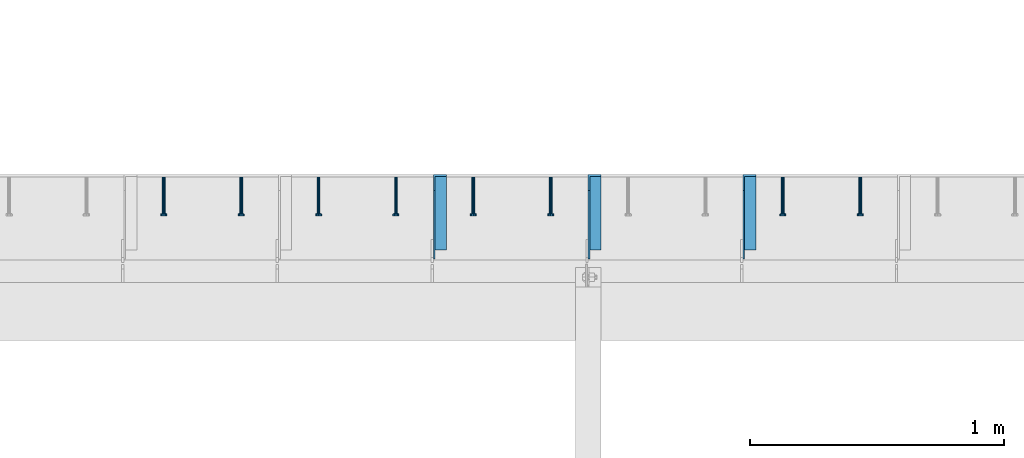
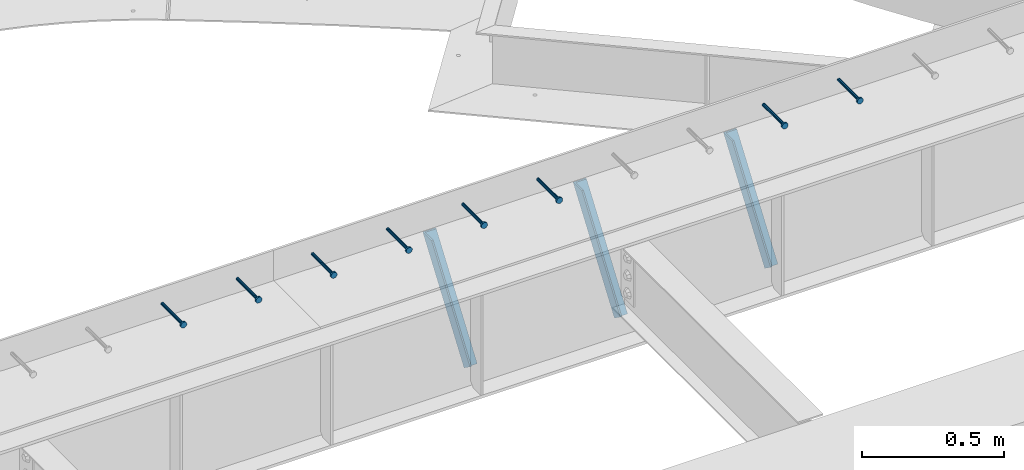
# One storey, part 1350 of 1763: 8 beams, 3 members, 9 elements without a shape of their own.
"""IFC2X3 building model written with IfcOpenShell, lengths in millimetres."""

from ifc_helpers import new_model, si_unit, frame, origin_with_axes, place, context, subcontext, project, spatial, faceted_brep, material, type_object, element, aggregate, save


model = new_model("IFC2X3")

# Units and contexts
model_context = context("Model", 3, precision=1e-05, world=origin_with_axes())
body_context = subcontext(model_context, "Body", "Model", "MODEL_VIEW")
ifc_project = project(units=[si_unit("LENGTHUNIT", "METRE", prefix="MILLI"), si_unit("AREAUNIT", "SQUARE_METRE"), si_unit("VOLUMEUNIT", "CUBIC_METRE"), si_unit("MASSUNIT", "GRAM", prefix="KILO"), si_unit("TIMEUNIT", "SECOND"), si_unit("PLANEANGLEUNIT", "RADIAN"), si_unit("SOLIDANGLEUNIT", "STERADIAN"), si_unit("THERMODYNAMICTEMPERATUREUNIT", "DEGREE_CELSIUS"), si_unit("LUMINOUSINTENSITYUNIT", "LUMEN")], contexts=[model_context])

# Site, building, storey
site_placement = place(None, origin_with_axes())
site = spatial("IfcSite", under=ifc_project, at=site_placement, CompositionType="ELEMENT")
building_placement = place(site_placement, origin_with_axes())
building = spatial("IfcBuilding", under=site, at=building_placement, Name="Undefined", CompositionType="ELEMENT")
storey_placement = place(building_placement, origin_with_axes())
storey = spatial("IfcBuildingStorey", under=building, at=storey_placement, Name="Undefined", CompositionType="ELEMENT", Elevation=0.0)

# Assembly, beam
assembly_1_placement = place(storey_placement, origin_with_axes())
assembly_1 = element("IfcElementAssembly", 1, at=assembly_1_placement, inside=storey, Name="HEADED STUD ANCHOR", AssemblyPlace="NOTDEFINED", PredefinedType="RIGID_FRAME")
ifc_material_1 = material(Name="STEEL/A108")
beam_type = type_object("IfcBeamType", PredefinedType="NOTDEFINED")
beam_1_placement = place(assembly_1_placement, frame((-53207.6747736983, 53984.5250183106, 5264.23140606069), z_axis=(0.0, 0.0, 1.0), x_axis=(0.0, -1.0, 0.0)))
beam_1 = element("IfcBeam", 2, at=beam_1_placement, type_object=beam_type, material=ifc_material_1, Name="HEADED STUD ANCHOR", context=body_context, shape_type="Brep", body=[
    faceted_brep([(0.0, -3.1800000667572, 5.5), (0.0, -5.5, 3.1800000667572), (141.732000000002, -5.5, 3.1800000667572), (141.732000000002, -3.1800000667572, 5.5), (0.0, -6.34999999999491, 1.45519152283669e-11), (141.732000000002, -6.34999990463257, 0.0), (0.0, -5.5, -3.1800000667572), (141.732000000002, -5.5, -3.1800000667572), (0.0, -3.1800000667572, -5.5), (141.732000000002, -3.1800000667572, -5.5), (0.0, 0.0, -6.34999990463257), (141.732000000002, 0.0, -6.34999990463257), (0.0, 3.1800000667572, -5.5), (141.732000000002, 3.1800000667572, -5.5), (0.0, 5.5, -3.1800000667572), (141.732000000002, 5.5, -3.1800000667572), (0.0, 6.34999999999491, -2.91038304567337e-11), (141.732000000002, 6.34999990463257, 0.0), (0.0, 5.5, 3.1800000667572), (141.732000000002, 5.5, 3.1800000667572), (0.0, 3.1800000667572, 5.5), (141.732000000002, 3.1800000667572, 5.5), (0.0, 0.0, 6.34999990463257), (141.732000000002, 0.0, 6.34999990463257), (144.780000000001, -10.9899997711182, 6.34999990463257), (144.780000000001, -6.34000015258789, 10.9899997711182), (144.780000000001, -12.6999998092651, 0.0), (144.780000000001, -10.9899997711182, -6.34999990463257), (144.780000000001, -6.34000015258789, -10.9899997711182), (144.780000000001, 0.0, -12.6899995803833), (144.780000000001, 6.34000015258789, -10.9899997711182), (144.780000000001, 10.9899997711182, -6.34999990463257), (144.780000000001, 12.6999998092651, 0.0), (144.780000000001, 10.9899997711182, 6.34999990463257), (144.780000000001, 6.34000015258789, 10.9899997711182), (144.780000000001, 0.0, 12.6899995803833), (152.400000000001, -10.9899997711182, 6.34999990463257), (152.400000000001, -6.34000015258789, 10.9899997711182), (152.400000000001, -12.6999998092651, 0.0), (152.400000000001, -10.9899997711182, -6.34999990463257), (152.400000000001, -6.34000015258789, -10.9899997711182), (152.400000000001, 0.0, -12.6899995803833), (152.400000000001, 6.34000015258789, -10.9899997711182), (152.400000000001, 10.9899997711182, -6.34999990463257), (152.400000000001, 12.6999998092651, 0.0), (152.400000000001, 10.9899997711182, 6.34999990463257), (152.400000000001, 6.34000015258789, 10.9899997711182), (152.400000000001, 0.0, 12.6899995803833)], [[[0, 1, 2, 3]], [[1, 4, 5, 2]], [[4, 6, 7, 5]], [[6, 8, 9, 7]], [[8, 10, 11, 9]], [[10, 12, 13, 11]], [[12, 14, 15, 13]], [[14, 16, 17, 15]], [[16, 18, 19, 17]], [[18, 20, 21, 19]], [[20, 22, 23, 21]], [[22, 0, 3, 23]], [[22, 20, 18, 16, 14, 12, 10, 8, 6, 4, 1, 0]], [[3, 2, 24, 25]], [[2, 5, 26, 24]], [[5, 7, 27, 26]], [[7, 9, 28, 27]], [[9, 11, 29, 28]], [[11, 13, 30, 29]], [[13, 15, 31, 30]], [[15, 17, 32, 31]], [[17, 19, 33, 32]], [[19, 21, 34, 33]], [[21, 23, 35, 34]], [[23, 3, 25, 35]], [[25, 24, 36, 37]], [[24, 26, 38, 36]], [[26, 27, 39, 38]], [[27, 28, 40, 39]], [[28, 29, 41, 40]], [[29, 30, 42, 41]], [[30, 31, 43, 42]], [[31, 32, 44, 43]], [[32, 33, 45, 44]], [[33, 34, 46, 45]], [[34, 35, 47, 46]], [[35, 25, 37, 47]], [[38, 39, 40, 41, 42, 43, 44, 45, 46, 47, 37, 36]]]),
])
aggregate(assembly_1, [beam_1])

assembly_2_placement = place(storey_placement, origin_with_axes())
assembly_2 = element("IfcElementAssembly", 3, at=assembly_2_placement, inside=storey, Name="HEADED STUD ANCHOR", AssemblyPlace="NOTDEFINED", PredefinedType="RIGID_FRAME")
beam_2_placement = place(assembly_2_placement, frame((-53512.4747736983, 53984.5250183106, 5264.23140606069), z_axis=(0.0, 0.0, 1.0), x_axis=(0.0, -1.0, 0.0)))
beam_2 = element("IfcBeam", 4, at=beam_2_placement, type_object=beam_type, material=ifc_material_1, Name="HEADED STUD ANCHOR", context=body_context, shape_type="Brep", body=[
    faceted_brep([(0.0, -3.1800000667572, 5.5), (0.0, -5.5, 3.1800000667572), (141.732000000002, -5.5, 3.1800000667572), (141.732000000002, -3.1800000667572, 5.5), (0.0, -6.34999999999491, 1.45519152283669e-11), (141.732000000002, -6.34999990463257, 0.0), (0.0, -5.5, -3.1800000667572), (141.732000000002, -5.5, -3.1800000667572), (0.0, -3.1800000667572, -5.5), (141.732000000002, -3.1800000667572, -5.5), (0.0, 0.0, -6.34999990463257), (141.732000000002, 0.0, -6.34999990463257), (0.0, 3.1800000667572, -5.5), (141.732000000002, 3.1800000667572, -5.5), (0.0, 5.5, -3.1800000667572), (141.732000000002, 5.5, -3.1800000667572), (0.0, 6.34999999999491, -2.91038304567337e-11), (141.732000000002, 6.34999990463257, 0.0), (0.0, 5.5, 3.1800000667572), (141.732000000002, 5.5, 3.1800000667572), (0.0, 3.1800000667572, 5.5), (141.732000000002, 3.1800000667572, 5.5), (0.0, 0.0, 6.34999990463257), (141.732000000002, 0.0, 6.34999990463257), (144.780000000001, -10.9899997711182, 6.34999990463257), (144.780000000001, -6.34000015258789, 10.9899997711182), (144.780000000001, -12.6999998092651, 0.0), (144.780000000001, -10.9899997711182, -6.34999990463257), (144.780000000001, -6.34000015258789, -10.9899997711182), (144.780000000001, 0.0, -12.6899995803833), (144.780000000001, 6.34000015258789, -10.9899997711182), (144.780000000001, 10.9899997711182, -6.34999990463257), (144.780000000001, 12.6999998092651, 0.0), (144.780000000001, 10.9899997711182, 6.34999990463257), (144.780000000001, 6.34000015258789, 10.9899997711182), (144.780000000001, 0.0, 12.6899995803833), (152.400000000001, -10.9899997711182, 6.34999990463257), (152.400000000001, -6.34000015258789, 10.9899997711182), (152.400000000001, -12.6999998092651, 0.0), (152.400000000001, -10.9899997711182, -6.34999990463257), (152.400000000001, -6.34000015258789, -10.9899997711182), (152.400000000001, 0.0, -12.6899995803833), (152.400000000001, 6.34000015258789, -10.9899997711182), (152.400000000001, 10.9899997711182, -6.34999990463257), (152.400000000001, 12.6999998092651, 0.0), (152.400000000001, 10.9899997711182, 6.34999990463257), (152.400000000001, 6.34000015258789, 10.9899997711182), (152.400000000001, 0.0, 12.6899995803833)], [[[0, 1, 2, 3]], [[1, 4, 5, 2]], [[4, 6, 7, 5]], [[6, 8, 9, 7]], [[8, 10, 11, 9]], [[10, 12, 13, 11]], [[12, 14, 15, 13]], [[14, 16, 17, 15]], [[16, 18, 19, 17]], [[18, 20, 21, 19]], [[20, 22, 23, 21]], [[22, 0, 3, 23]], [[22, 20, 18, 16, 14, 12, 10, 8, 6, 4, 1, 0]], [[3, 2, 24, 25]], [[2, 5, 26, 24]], [[5, 7, 27, 26]], [[7, 9, 28, 27]], [[9, 11, 29, 28]], [[11, 13, 30, 29]], [[13, 15, 31, 30]], [[15, 17, 32, 31]], [[17, 19, 33, 32]], [[19, 21, 34, 33]], [[21, 23, 35, 34]], [[23, 3, 25, 35]], [[25, 24, 36, 37]], [[24, 26, 38, 36]], [[26, 27, 39, 38]], [[27, 28, 40, 39]], [[28, 29, 41, 40]], [[29, 30, 42, 41]], [[30, 31, 43, 42]], [[31, 32, 44, 43]], [[32, 33, 45, 44]], [[33, 34, 46, 45]], [[34, 35, 47, 46]], [[35, 25, 37, 47]], [[38, 39, 40, 41, 42, 43, 44, 45, 46, 47, 37, 36]]]),
])
aggregate(assembly_2, [beam_2])

assembly_3_placement = place(storey_placement, origin_with_axes())
assembly_3 = element("IfcElementAssembly", 5, at=assembly_3_placement, inside=storey, Name="HEADED STUD ANCHOR", AssemblyPlace="NOTDEFINED", PredefinedType="RIGID_FRAME")
beam_3_placement = place(assembly_3_placement, frame((-54426.8747736983, 53984.5250183106, 5264.23140606069), z_axis=(0.0, 0.0, 1.0), x_axis=(0.0, -1.0, 0.0)))
beam_3 = element("IfcBeam", 6, at=beam_3_placement, type_object=beam_type, material=ifc_material_1, Name="HEADED STUD ANCHOR", context=body_context, shape_type="Brep", body=[
    faceted_brep([(0.0, -3.1800000667572, 5.5), (0.0, -5.5, 3.1800000667572), (141.732000000002, -5.5, 3.1800000667572), (141.732000000002, -3.1800000667572, 5.5), (0.0, -6.34999999999491, 1.45519152283669e-11), (141.732000000002, -6.34999990463257, 0.0), (0.0, -5.5, -3.1800000667572), (141.732000000002, -5.5, -3.1800000667572), (0.0, -3.1800000667572, -5.5), (141.732000000002, -3.1800000667572, -5.5), (0.0, 0.0, -6.34999990463257), (141.732000000002, 0.0, -6.34999990463257), (0.0, 3.1800000667572, -5.5), (141.732000000002, 3.1800000667572, -5.5), (0.0, 5.5, -3.1800000667572), (141.732000000002, 5.5, -3.1800000667572), (0.0, 6.34999999999491, -2.91038304567337e-11), (141.732000000002, 6.34999990463257, 0.0), (0.0, 5.5, 3.1800000667572), (141.732000000002, 5.5, 3.1800000667572), (0.0, 3.1800000667572, 5.5), (141.732000000002, 3.1800000667572, 5.5), (0.0, 0.0, 6.34999990463257), (141.732000000002, 0.0, 6.34999990463257), (144.780000000001, -10.9899997711182, 6.34999990463257), (144.780000000001, -6.34000015258789, 10.9899997711182), (144.780000000001, -12.6999998092651, 0.0), (144.780000000001, -10.9899997711182, -6.34999990463257), (144.780000000001, -6.34000015258789, -10.9899997711182), (144.780000000001, 0.0, -12.6899995803833), (144.780000000001, 6.34000015258789, -10.9899997711182), (144.780000000001, 10.9899997711182, -6.34999990463257), (144.780000000001, 12.6999998092651, 0.0), (144.780000000001, 10.9899997711182, 6.34999990463257), (144.780000000001, 6.34000015258789, 10.9899997711182), (144.780000000001, 0.0, 12.6899995803833), (152.400000000001, -10.9899997711182, 6.34999990463257), (152.400000000001, -6.34000015258789, 10.9899997711182), (152.400000000001, -12.6999998092651, 0.0), (152.400000000001, -10.9899997711182, -6.34999990463257), (152.400000000001, -6.34000015258789, -10.9899997711182), (152.400000000001, 0.0, -12.6899995803833), (152.400000000001, 6.34000015258789, -10.9899997711182), (152.400000000001, 10.9899997711182, -6.34999990463257), (152.400000000001, 12.6999998092651, 0.0), (152.400000000001, 10.9899997711182, 6.34999990463257), (152.400000000001, 6.34000015258789, 10.9899997711182), (152.400000000001, 0.0, 12.6899995803833)], [[[0, 1, 2, 3]], [[1, 4, 5, 2]], [[4, 6, 7, 5]], [[6, 8, 9, 7]], [[8, 10, 11, 9]], [[10, 12, 13, 11]], [[12, 14, 15, 13]], [[14, 16, 17, 15]], [[16, 18, 19, 17]], [[18, 20, 21, 19]], [[20, 22, 23, 21]], [[22, 0, 3, 23]], [[22, 20, 18, 16, 14, 12, 10, 8, 6, 4, 1, 0]], [[3, 2, 24, 25]], [[2, 5, 26, 24]], [[5, 7, 27, 26]], [[7, 9, 28, 27]], [[9, 11, 29, 28]], [[11, 13, 30, 29]], [[13, 15, 31, 30]], [[15, 17, 32, 31]], [[17, 19, 33, 32]], [[19, 21, 34, 33]], [[21, 23, 35, 34]], [[23, 3, 25, 35]], [[25, 24, 36, 37]], [[24, 26, 38, 36]], [[26, 27, 39, 38]], [[27, 28, 40, 39]], [[28, 29, 41, 40]], [[29, 30, 42, 41]], [[30, 31, 43, 42]], [[31, 32, 44, 43]], [[32, 33, 45, 44]], [[33, 34, 46, 45]], [[34, 35, 47, 46]], [[35, 25, 37, 47]], [[38, 39, 40, 41, 42, 43, 44, 45, 46, 47, 37, 36]]]),
])
aggregate(assembly_3, [beam_3])

assembly_4_placement = place(storey_placement, origin_with_axes())
assembly_4 = element("IfcElementAssembly", 7, at=assembly_4_placement, inside=storey, Name="HEADED STUD ANCHOR", AssemblyPlace="NOTDEFINED", PredefinedType="RIGID_FRAME")
beam_4_placement = place(assembly_4_placement, frame((-54731.6747736983, 53984.5250183106, 5264.23140606069), z_axis=(0.0, 0.0, 1.0), x_axis=(0.0, -1.0, 0.0)))
beam_4 = element("IfcBeam", 8, at=beam_4_placement, type_object=beam_type, material=ifc_material_1, Name="HEADED STUD ANCHOR", context=body_context, shape_type="Brep", body=[
    faceted_brep([(0.0, -3.1800000667572, 5.5), (0.0, -5.5, 3.1800000667572), (141.732000000002, -5.5, 3.1800000667572), (141.732000000002, -3.1800000667572, 5.5), (0.0, -6.34999999999491, 1.45519152283669e-11), (141.732000000002, -6.34999990463257, 0.0), (0.0, -5.5, -3.1800000667572), (141.732000000002, -5.5, -3.1800000667572), (0.0, -3.1800000667572, -5.5), (141.732000000002, -3.1800000667572, -5.5), (0.0, 0.0, -6.34999990463257), (141.732000000002, 0.0, -6.34999990463257), (0.0, 3.1800000667572, -5.5), (141.732000000002, 3.1800000667572, -5.5), (0.0, 5.5, -3.1800000667572), (141.732000000002, 5.5, -3.1800000667572), (0.0, 6.34999999999491, -2.91038304567337e-11), (141.732000000002, 6.34999990463257, 0.0), (0.0, 5.5, 3.1800000667572), (141.732000000002, 5.5, 3.1800000667572), (0.0, 3.1800000667572, 5.5), (141.732000000002, 3.1800000667572, 5.5), (0.0, 0.0, 6.34999990463257), (141.732000000002, 0.0, 6.34999990463257), (144.780000000001, -10.9899997711182, 6.34999990463257), (144.780000000001, -6.34000015258789, 10.9899997711182), (144.780000000001, -12.6999998092651, 0.0), (144.780000000001, -10.9899997711182, -6.34999990463257), (144.780000000001, -6.34000015258789, -10.9899997711182), (144.780000000001, 0.0, -12.6899995803833), (144.780000000001, 6.34000015258789, -10.9899997711182), (144.780000000001, 10.9899997711182, -6.34999990463257), (144.780000000001, 12.6999998092651, 0.0), (144.780000000001, 10.9899997711182, 6.34999990463257), (144.780000000001, 6.34000015258789, 10.9899997711182), (144.780000000001, 0.0, 12.6899995803833), (152.400000000001, -10.9899997711182, 6.34999990463257), (152.400000000001, -6.34000015258789, 10.9899997711182), (152.400000000001, -12.6999998092651, 0.0), (152.400000000001, -10.9899997711182, -6.34999990463257), (152.400000000001, -6.34000015258789, -10.9899997711182), (152.400000000001, 0.0, -12.6899995803833), (152.400000000001, 6.34000015258789, -10.9899997711182), (152.400000000001, 10.9899997711182, -6.34999990463257), (152.400000000001, 12.6999998092651, 0.0), (152.400000000001, 10.9899997711182, 6.34999990463257), (152.400000000001, 6.34000015258789, 10.9899997711182), (152.400000000001, 0.0, 12.6899995803833)], [[[0, 1, 2, 3]], [[1, 4, 5, 2]], [[4, 6, 7, 5]], [[6, 8, 9, 7]], [[8, 10, 11, 9]], [[10, 12, 13, 11]], [[12, 14, 15, 13]], [[14, 16, 17, 15]], [[16, 18, 19, 17]], [[18, 20, 21, 19]], [[20, 22, 23, 21]], [[22, 0, 3, 23]], [[22, 20, 18, 16, 14, 12, 10, 8, 6, 4, 1, 0]], [[3, 2, 24, 25]], [[2, 5, 26, 24]], [[5, 7, 27, 26]], [[7, 9, 28, 27]], [[9, 11, 29, 28]], [[11, 13, 30, 29]], [[13, 15, 31, 30]], [[15, 17, 32, 31]], [[17, 19, 33, 32]], [[19, 21, 34, 33]], [[21, 23, 35, 34]], [[23, 3, 25, 35]], [[25, 24, 36, 37]], [[24, 26, 38, 36]], [[26, 27, 39, 38]], [[27, 28, 40, 39]], [[28, 29, 41, 40]], [[29, 30, 42, 41]], [[30, 31, 43, 42]], [[31, 32, 44, 43]], [[32, 33, 45, 44]], [[33, 34, 46, 45]], [[34, 35, 47, 46]], [[35, 25, 37, 47]], [[38, 39, 40, 41, 42, 43, 44, 45, 46, 47, 37, 36]]]),
])
aggregate(assembly_4, [beam_4])

assembly_5_placement = place(storey_placement, origin_with_axes())
assembly_5 = element("IfcElementAssembly", 9, at=assembly_5_placement, inside=storey, Name="HEADED STUD ANCHOR", AssemblyPlace="NOTDEFINED", PredefinedType="RIGID_FRAME")
beam_5_placement = place(assembly_5_placement, frame((-55036.4747736983, 53984.5250183106, 5264.23140606069), z_axis=(0.0, 0.0, 1.0), x_axis=(0.0, -1.0, 0.0)))
beam_5 = element("IfcBeam", 10, at=beam_5_placement, type_object=beam_type, material=ifc_material_1, Name="HEADED STUD ANCHOR", context=body_context, shape_type="Brep", body=[
    faceted_brep([(0.0, -3.1800000667572, 5.5), (0.0, -5.5, 3.1800000667572), (141.732000000002, -5.5, 3.1800000667572), (141.732000000002, -3.1800000667572, 5.5), (0.0, -6.34999999999491, 1.45519152283669e-11), (141.732000000002, -6.34999990463257, 0.0), (0.0, -5.5, -3.1800000667572), (141.732000000002, -5.5, -3.1800000667572), (0.0, -3.1800000667572, -5.5), (141.732000000002, -3.1800000667572, -5.5), (0.0, 0.0, -6.34999990463257), (141.732000000002, 0.0, -6.34999990463257), (0.0, 3.1800000667572, -5.5), (141.732000000002, 3.1800000667572, -5.5), (0.0, 5.5, -3.1800000667572), (141.732000000002, 5.5, -3.1800000667572), (0.0, 6.34999999999491, -2.91038304567337e-11), (141.732000000002, 6.34999990463257, 0.0), (0.0, 5.5, 3.1800000667572), (141.732000000002, 5.5, 3.1800000667572), (0.0, 3.1800000667572, 5.5), (141.732000000002, 3.1800000667572, 5.5), (0.0, 0.0, 6.34999990463257), (141.732000000002, 0.0, 6.34999990463257), (144.780000000001, -10.9899997711182, 6.34999990463257), (144.780000000001, -6.34000015258789, 10.9899997711182), (144.780000000001, -12.6999998092651, 0.0), (144.780000000001, -10.9899997711182, -6.34999990463257), (144.780000000001, -6.34000015258789, -10.9899997711182), (144.780000000001, 0.0, -12.6899995803833), (144.780000000001, 6.34000015258789, -10.9899997711182), (144.780000000001, 10.9899997711182, -6.34999990463257), (144.780000000001, 12.6999998092651, 0.0), (144.780000000001, 10.9899997711182, 6.34999990463257), (144.780000000001, 6.34000015258789, 10.9899997711182), (144.780000000001, 0.0, 12.6899995803833), (152.400000000001, -10.9899997711182, 6.34999990463257), (152.400000000001, -6.34000015258789, 10.9899997711182), (152.400000000001, -12.6999998092651, 0.0), (152.400000000001, -10.9899997711182, -6.34999990463257), (152.400000000001, -6.34000015258789, -10.9899997711182), (152.400000000001, 0.0, -12.6899995803833), (152.400000000001, 6.34000015258789, -10.9899997711182), (152.400000000001, 10.9899997711182, -6.34999990463257), (152.400000000001, 12.6999998092651, 0.0), (152.400000000001, 10.9899997711182, 6.34999990463257), (152.400000000001, 6.34000015258789, 10.9899997711182), (152.400000000001, 0.0, 12.6899995803833)], [[[0, 1, 2, 3]], [[1, 4, 5, 2]], [[4, 6, 7, 5]], [[6, 8, 9, 7]], [[8, 10, 11, 9]], [[10, 12, 13, 11]], [[12, 14, 15, 13]], [[14, 16, 17, 15]], [[16, 18, 19, 17]], [[18, 20, 21, 19]], [[20, 22, 23, 21]], [[22, 0, 3, 23]], [[22, 20, 18, 16, 14, 12, 10, 8, 6, 4, 1, 0]], [[3, 2, 24, 25]], [[2, 5, 26, 24]], [[5, 7, 27, 26]], [[7, 9, 28, 27]], [[9, 11, 29, 28]], [[11, 13, 30, 29]], [[13, 15, 31, 30]], [[15, 17, 32, 31]], [[17, 19, 33, 32]], [[19, 21, 34, 33]], [[21, 23, 35, 34]], [[23, 3, 25, 35]], [[25, 24, 36, 37]], [[24, 26, 38, 36]], [[26, 27, 39, 38]], [[27, 28, 40, 39]], [[28, 29, 41, 40]], [[29, 30, 42, 41]], [[30, 31, 43, 42]], [[31, 32, 44, 43]], [[32, 33, 45, 44]], [[33, 34, 46, 45]], [[34, 35, 47, 46]], [[35, 25, 37, 47]], [[38, 39, 40, 41, 42, 43, 44, 45, 46, 47, 37, 36]]]),
])
aggregate(assembly_5, [beam_5])

assembly_6_placement = place(storey_placement, origin_with_axes())
assembly_6 = element("IfcElementAssembly", 11, at=assembly_6_placement, inside=storey, Name="HEADED STUD ANCHOR", AssemblyPlace="NOTDEFINED", PredefinedType="RIGID_FRAME")
beam_6_placement = place(assembly_6_placement, frame((-55341.2747736983, 53984.5250183106, 5264.23140606069), z_axis=(0.0, 0.0, 1.0), x_axis=(0.0, -1.0, 0.0)))
beam_6 = element("IfcBeam", 12, at=beam_6_placement, type_object=beam_type, material=ifc_material_1, Name="HEADED STUD ANCHOR", context=body_context, shape_type="Brep", body=[
    faceted_brep([(0.0, -3.1800000667572, 5.5), (0.0, -5.5, 3.1800000667572), (141.732000000002, -5.5, 3.1800000667572), (141.732000000002, -3.1800000667572, 5.5), (0.0, -6.34999999999491, 1.45519152283669e-11), (141.732000000002, -6.34999990463257, 0.0), (0.0, -5.5, -3.1800000667572), (141.732000000002, -5.5, -3.1800000667572), (0.0, -3.1800000667572, -5.5), (141.732000000002, -3.1800000667572, -5.5), (0.0, 0.0, -6.34999990463257), (141.732000000002, 0.0, -6.34999990463257), (0.0, 3.1800000667572, -5.5), (141.732000000002, 3.1800000667572, -5.5), (0.0, 5.5, -3.1800000667572), (141.732000000002, 5.5, -3.1800000667572), (0.0, 6.34999999999491, -2.91038304567337e-11), (141.732000000002, 6.34999990463257, 0.0), (0.0, 5.5, 3.1800000667572), (141.732000000002, 5.5, 3.1800000667572), (0.0, 3.1800000667572, 5.5), (141.732000000002, 3.1800000667572, 5.5), (0.0, 0.0, 6.34999990463257), (141.732000000002, 0.0, 6.34999990463257), (144.780000000001, -10.9899997711182, 6.34999990463257), (144.780000000001, -6.34000015258789, 10.9899997711182), (144.780000000001, -12.6999998092651, 0.0), (144.780000000001, -10.9899997711182, -6.34999990463257), (144.780000000001, -6.34000015258789, -10.9899997711182), (144.780000000001, 0.0, -12.6899995803833), (144.780000000001, 6.34000015258789, -10.9899997711182), (144.780000000001, 10.9899997711182, -6.34999990463257), (144.780000000001, 12.6999998092651, 0.0), (144.780000000001, 10.9899997711182, 6.34999990463257), (144.780000000001, 6.34000015258789, 10.9899997711182), (144.780000000001, 0.0, 12.6899995803833), (152.400000000001, -10.9899997711182, 6.34999990463257), (152.400000000001, -6.34000015258789, 10.9899997711182), (152.400000000001, -12.6999998092651, 0.0), (152.400000000001, -10.9899997711182, -6.34999990463257), (152.400000000001, -6.34000015258789, -10.9899997711182), (152.400000000001, 0.0, -12.6899995803833), (152.400000000001, 6.34000015258789, -10.9899997711182), (152.400000000001, 10.9899997711182, -6.34999990463257), (152.400000000001, 12.6999998092651, 0.0), (152.400000000001, 10.9899997711182, 6.34999990463257), (152.400000000001, 6.34000015258789, 10.9899997711182), (152.400000000001, 0.0, 12.6899995803833)], [[[0, 1, 2, 3]], [[1, 4, 5, 2]], [[4, 6, 7, 5]], [[6, 8, 9, 7]], [[8, 10, 11, 9]], [[10, 12, 13, 11]], [[12, 14, 15, 13]], [[14, 16, 17, 15]], [[16, 18, 19, 17]], [[18, 20, 21, 19]], [[20, 22, 23, 21]], [[22, 0, 3, 23]], [[22, 20, 18, 16, 14, 12, 10, 8, 6, 4, 1, 0]], [[3, 2, 24, 25]], [[2, 5, 26, 24]], [[5, 7, 27, 26]], [[7, 9, 28, 27]], [[9, 11, 29, 28]], [[11, 13, 30, 29]], [[13, 15, 31, 30]], [[15, 17, 32, 31]], [[17, 19, 33, 32]], [[19, 21, 34, 33]], [[21, 23, 35, 34]], [[23, 3, 25, 35]], [[25, 24, 36, 37]], [[24, 26, 38, 36]], [[26, 27, 39, 38]], [[27, 28, 40, 39]], [[28, 29, 41, 40]], [[29, 30, 42, 41]], [[30, 31, 43, 42]], [[31, 32, 44, 43]], [[32, 33, 45, 44]], [[33, 34, 46, 45]], [[34, 35, 47, 46]], [[35, 25, 37, 47]], [[38, 39, 40, 41, 42, 43, 44, 45, 46, 47, 37, 36]]]),
])
aggregate(assembly_6, [beam_6])

assembly_7_placement = place(storey_placement, origin_with_axes())
assembly_7 = element("IfcElementAssembly", 13, at=assembly_7_placement, inside=storey, Name="HEADED STUD ANCHOR", AssemblyPlace="NOTDEFINED", PredefinedType="RIGID_FRAME")
beam_7_placement = place(assembly_7_placement, frame((-55646.0747736983, 53984.5250183106, 5264.23140606069), z_axis=(0.0, 0.0, 1.0), x_axis=(0.0, -1.0, 0.0)))
beam_7 = element("IfcBeam", 14, at=beam_7_placement, type_object=beam_type, material=ifc_material_1, Name="HEADED STUD ANCHOR", context=body_context, shape_type="Brep", body=[
    faceted_brep([(0.0, -3.1800000667572, 5.5), (0.0, -5.5, 3.1800000667572), (141.732000000002, -5.5, 3.1800000667572), (141.732000000002, -3.1800000667572, 5.5), (0.0, -6.34999999999491, 1.45519152283669e-11), (141.732000000002, -6.34999990463257, 0.0), (0.0, -5.5, -3.1800000667572), (141.732000000002, -5.5, -3.1800000667572), (0.0, -3.1800000667572, -5.5), (141.732000000002, -3.1800000667572, -5.5), (0.0, 0.0, -6.34999990463257), (141.732000000002, 0.0, -6.34999990463257), (0.0, 3.1800000667572, -5.5), (141.732000000002, 3.1800000667572, -5.5), (0.0, 5.5, -3.1800000667572), (141.732000000002, 5.5, -3.1800000667572), (0.0, 6.34999999999491, -2.91038304567337e-11), (141.732000000002, 6.34999990463257, 0.0), (0.0, 5.5, 3.1800000667572), (141.732000000002, 5.5, 3.1800000667572), (0.0, 3.1800000667572, 5.5), (141.732000000002, 3.1800000667572, 5.5), (0.0, 0.0, 6.34999990463257), (141.732000000002, 0.0, 6.34999990463257), (144.780000000001, -10.9899997711182, 6.34999990463257), (144.780000000001, -6.34000015258789, 10.9899997711182), (144.780000000001, -12.6999998092651, 0.0), (144.780000000001, -10.9899997711182, -6.34999990463257), (144.780000000001, -6.34000015258789, -10.9899997711182), (144.780000000001, 0.0, -12.6899995803833), (144.780000000001, 6.34000015258789, -10.9899997711182), (144.780000000001, 10.9899997711182, -6.34999990463257), (144.780000000001, 12.6999998092651, 0.0), (144.780000000001, 10.9899997711182, 6.34999990463257), (144.780000000001, 6.34000015258789, 10.9899997711182), (144.780000000001, 0.0, 12.6899995803833), (152.400000000001, -10.9899997711182, 6.34999990463257), (152.400000000001, -6.34000015258789, 10.9899997711182), (152.400000000001, -12.6999998092651, 0.0), (152.400000000001, -10.9899997711182, -6.34999990463257), (152.400000000001, -6.34000015258789, -10.9899997711182), (152.400000000001, 0.0, -12.6899995803833), (152.400000000001, 6.34000015258789, -10.9899997711182), (152.400000000001, 10.9899997711182, -6.34999990463257), (152.400000000001, 12.6999998092651, 0.0), (152.400000000001, 10.9899997711182, 6.34999990463257), (152.400000000001, 6.34000015258789, 10.9899997711182), (152.400000000001, 0.0, 12.6899995803833)], [[[0, 1, 2, 3]], [[1, 4, 5, 2]], [[4, 6, 7, 5]], [[6, 8, 9, 7]], [[8, 10, 11, 9]], [[10, 12, 13, 11]], [[12, 14, 15, 13]], [[14, 16, 17, 15]], [[16, 18, 19, 17]], [[18, 20, 21, 19]], [[20, 22, 23, 21]], [[22, 0, 3, 23]], [[22, 20, 18, 16, 14, 12, 10, 8, 6, 4, 1, 0]], [[3, 2, 24, 25]], [[2, 5, 26, 24]], [[5, 7, 27, 26]], [[7, 9, 28, 27]], [[9, 11, 29, 28]], [[11, 13, 30, 29]], [[13, 15, 31, 30]], [[15, 17, 32, 31]], [[17, 19, 33, 32]], [[19, 21, 34, 33]], [[21, 23, 35, 34]], [[23, 3, 25, 35]], [[25, 24, 36, 37]], [[24, 26, 38, 36]], [[26, 27, 39, 38]], [[27, 28, 40, 39]], [[28, 29, 41, 40]], [[29, 30, 42, 41]], [[30, 31, 43, 42]], [[31, 32, 44, 43]], [[32, 33, 45, 44]], [[33, 34, 46, 45]], [[34, 35, 47, 46]], [[35, 25, 37, 47]], [[38, 39, 40, 41, 42, 43, 44, 45, 46, 47, 37, 36]]]),
])
aggregate(assembly_7, [beam_7])

assembly_8_placement = place(storey_placement, origin_with_axes())
assembly_8 = element("IfcElementAssembly", 15, at=assembly_8_placement, inside=storey, Name="HEADED STUD ANCHOR", AssemblyPlace="NOTDEFINED", PredefinedType="RIGID_FRAME")
beam_8_placement = place(assembly_8_placement, frame((-55950.8747736983, 53984.5250183106, 5264.23140606069), z_axis=(0.0, 0.0, 1.0), x_axis=(0.0, -1.0, 0.0)))
beam_8 = element("IfcBeam", 16, at=beam_8_placement, type_object=beam_type, material=ifc_material_1, Name="HEADED STUD ANCHOR", context=body_context, shape_type="Brep", body=[
    faceted_brep([(0.0, -3.1800000667572, 5.5), (0.0, -5.5, 3.1800000667572), (141.732000000002, -5.5, 3.1800000667572), (141.732000000002, -3.1800000667572, 5.5), (0.0, -6.34999999999491, 1.45519152283669e-11), (141.732000000002, -6.34999990463257, 0.0), (0.0, -5.5, -3.1800000667572), (141.732000000002, -5.5, -3.1800000667572), (0.0, -3.1800000667572, -5.5), (141.732000000002, -3.1800000667572, -5.5), (0.0, 0.0, -6.34999990463257), (141.732000000002, 0.0, -6.34999990463257), (0.0, 3.1800000667572, -5.5), (141.732000000002, 3.1800000667572, -5.5), (0.0, 5.5, -3.1800000667572), (141.732000000002, 5.5, -3.1800000667572), (0.0, 6.34999999999491, -2.91038304567337e-11), (141.732000000002, 6.34999990463257, 0.0), (0.0, 5.5, 3.1800000667572), (141.732000000002, 5.5, 3.1800000667572), (0.0, 3.1800000667572, 5.5), (141.732000000002, 3.1800000667572, 5.5), (0.0, 0.0, 6.34999990463257), (141.732000000002, 0.0, 6.34999990463257), (144.780000000001, -10.9899997711182, 6.34999990463257), (144.780000000001, -6.34000015258789, 10.9899997711182), (144.780000000001, -12.6999998092651, 0.0), (144.780000000001, -10.9899997711182, -6.34999990463257), (144.780000000001, -6.34000015258789, -10.9899997711182), (144.780000000001, 0.0, -12.6899995803833), (144.780000000001, 6.34000015258789, -10.9899997711182), (144.780000000001, 10.9899997711182, -6.34999990463257), (144.780000000001, 12.6999998092651, 0.0), (144.780000000001, 10.9899997711182, 6.34999990463257), (144.780000000001, 6.34000015258789, 10.9899997711182), (144.780000000001, 0.0, 12.6899995803833), (152.400000000001, -10.9899997711182, 6.34999990463257), (152.400000000001, -6.34000015258789, 10.9899997711182), (152.400000000001, -12.6999998092651, 0.0), (152.400000000001, -10.9899997711182, -6.34999990463257), (152.400000000001, -6.34000015258789, -10.9899997711182), (152.400000000001, 0.0, -12.6899995803833), (152.400000000001, 6.34000015258789, -10.9899997711182), (152.400000000001, 10.9899997711182, -6.34999990463257), (152.400000000001, 12.6999998092651, 0.0), (152.400000000001, 10.9899997711182, 6.34999990463257), (152.400000000001, 6.34000015258789, 10.9899997711182), (152.400000000001, 0.0, 12.6899995803833)], [[[0, 1, 2, 3]], [[1, 4, 5, 2]], [[4, 6, 7, 5]], [[6, 8, 9, 7]], [[8, 10, 11, 9]], [[10, 12, 13, 11]], [[12, 14, 15, 13]], [[14, 16, 17, 15]], [[16, 18, 19, 17]], [[18, 20, 21, 19]], [[20, 22, 23, 21]], [[22, 0, 3, 23]], [[22, 20, 18, 16, 14, 12, 10, 8, 6, 4, 1, 0]], [[3, 2, 24, 25]], [[2, 5, 26, 24]], [[5, 7, 27, 26]], [[7, 9, 28, 27]], [[9, 11, 29, 28]], [[11, 13, 30, 29]], [[13, 15, 31, 30]], [[15, 17, 32, 31]], [[17, 19, 33, 32]], [[19, 21, 34, 33]], [[21, 23, 35, 34]], [[23, 3, 25, 35]], [[25, 24, 36, 37]], [[24, 26, 38, 36]], [[26, 27, 39, 38]], [[27, 28, 40, 39]], [[28, 29, 41, 40]], [[29, 30, 42, 41]], [[30, 31, 43, 42]], [[31, 32, 44, 43]], [[32, 33, 45, 44]], [[33, 34, 46, 45]], [[34, 35, 47, 46]], [[35, 25, 37, 47]], [[38, 39, 40, 41, 42, 43, 44, 45, 46, 47, 37, 36]]]),
])
aggregate(assembly_8, [beam_8])

# Assembly, members
assembly_9_placement = place(storey_placement, origin_with_axes())
assembly_9 = element("IfcElementAssembly", 17, at=assembly_9_placement, inside=storey, Name="BEAM", AssemblyPlace="NOTDEFINED", PredefinedType="RIGID_FRAME")
ifc_material_2 = material(Name="STEEL/A36")
member_type = type_object("IfcMemberType", Name="L2X2X1/4", PredefinedType="NOTDEFINED")
member_1_placement = place(assembly_9_placement, frame((-54253.8372736984, 53682.7083833992, 4801.551610525), z_axis=(0.0, -0.814117947745209, 0.580699549818259), x_axis=(0.0, 0.58069954981826, 0.814117947745209)))
member_1 = element("IfcMember", 18, at=member_1_placement, type_object=member_type, material=ifc_material_2, Name="ANGLE", ObjectType="L2X2X1/4", context=body_context, shape_type="Brep", body=[
    faceted_brep([(-1.45519152283669e-11, 25.4000000000015, -25.3999999999869), (1.45519152283669e-11, 25.4000000000015, 25.3999999999796), (464.304493432646, 25.4000000000015, 25.3999999991429), (500.539460322936, 25.4000000000015, -25.4000000009546), (1.45519152283669e-11, 19.0499999999993, 25.3999999999796), (464.304493432646, 19.0500000000029, 25.3999999991429), (-7.27595761418343e-12, 19.0499999999993, -19.0499999999956), (496.010089461648, 19.0500000000029, -19.0500000009415), (-7.27595761418343e-12, -25.4000000000015, -19.0499999999956), (496.010089461648, -25.4000000000015, -19.0500000009415), (-1.45519152283669e-11, -25.4000000000015, -25.3999999999869), (500.539460322936, -25.4000000000015, -25.4000000009546)], [[[0, 1, 2, 3]], [[1, 4, 5, 2]], [[4, 6, 7, 5]], [[6, 8, 9, 7]], [[8, 10, 11, 9]], [[10, 0, 3, 11]], [[5, 7, 9, 11, 3, 2]], [[10, 8, 6, 4, 1, 0]]]),
])
member_2_placement = place(assembly_9_placement, frame((-53644.2372736984, 53682.7083833992, 4801.551610525), z_axis=(0.0, -0.814117947745209, 0.580699549818259), x_axis=(0.0, 0.58069954981826, 0.814117947745209)))
member_2 = element("IfcMember", 19, at=member_2_placement, type_object=member_type, material=ifc_material_2, Name="ANGLE", ObjectType="L2X2X1/4", context=body_context, shape_type="Brep", body=[
    faceted_brep([(-1.45519152283669e-11, 25.4000000000015, -25.3999999999869), (1.45519152283669e-11, 25.4000000000015, 25.3999999999796), (464.304493432646, 25.4000000000015, 25.3999999991429), (500.539460322936, 25.4000000000015, -25.4000000009546), (1.45519152283669e-11, 19.0499999999993, 25.3999999999796), (464.304493432646, 19.0500000000029, 25.3999999991429), (-7.27595761418343e-12, 19.0499999999993, -19.0499999999956), (496.010089461648, 19.0500000000029, -19.0500000009415), (-7.27595761418343e-12, -25.4000000000015, -19.0499999999956), (496.010089461648, -25.4000000000015, -19.0500000009415), (-1.45519152283669e-11, -25.4000000000015, -25.3999999999869), (500.539460322936, -25.4000000000015, -25.4000000009546)], [[[0, 1, 2, 3]], [[1, 4, 5, 2]], [[4, 6, 7, 5]], [[6, 8, 9, 7]], [[8, 10, 11, 9]], [[10, 0, 3, 11]], [[5, 7, 9, 11, 3, 2]], [[10, 8, 6, 4, 1, 0]]]),
])
member_3_placement = place(assembly_9_placement, frame((-54863.4372736984, 53682.7083833992, 4801.551610525), z_axis=(0.0, -0.814117947745209, 0.580699549818259), x_axis=(0.0, 0.58069954981826, 0.814117947745209)))
member_3 = element("IfcMember", 20, at=member_3_placement, type_object=member_type, material=ifc_material_2, Name="ANGLE", ObjectType="L2X2X1/4", context=body_context, shape_type="Brep", body=[
    faceted_brep([(-1.45519152283669e-11, 25.4000000000015, -25.3999999999869), (1.45519152283669e-11, 25.4000000000015, 25.3999999999796), (464.304493432646, 25.4000000000015, 25.3999999991429), (500.539460322936, 25.4000000000015, -25.4000000009546), (1.45519152283669e-11, 19.0499999999993, 25.3999999999796), (464.304493432646, 19.0500000000029, 25.3999999991429), (-7.27595761418343e-12, 19.0499999999993, -19.0499999999956), (496.010089461648, 19.0500000000029, -19.0500000009415), (-7.27595761418343e-12, -25.4000000000015, -19.0499999999956), (496.010089461648, -25.4000000000015, -19.0500000009415), (-1.45519152283669e-11, -25.4000000000015, -25.3999999999869), (500.539460322936, -25.4000000000015, -25.4000000009546)], [[[0, 1, 2, 3]], [[1, 4, 5, 2]], [[4, 6, 7, 5]], [[6, 8, 9, 7]], [[8, 10, 11, 9]], [[10, 0, 3, 11]], [[5, 7, 9, 11, 3, 2]], [[10, 8, 6, 4, 1, 0]]]),
])
aggregate(assembly_9, [member_1, member_2, member_3])

save(model, "model.ifc")
